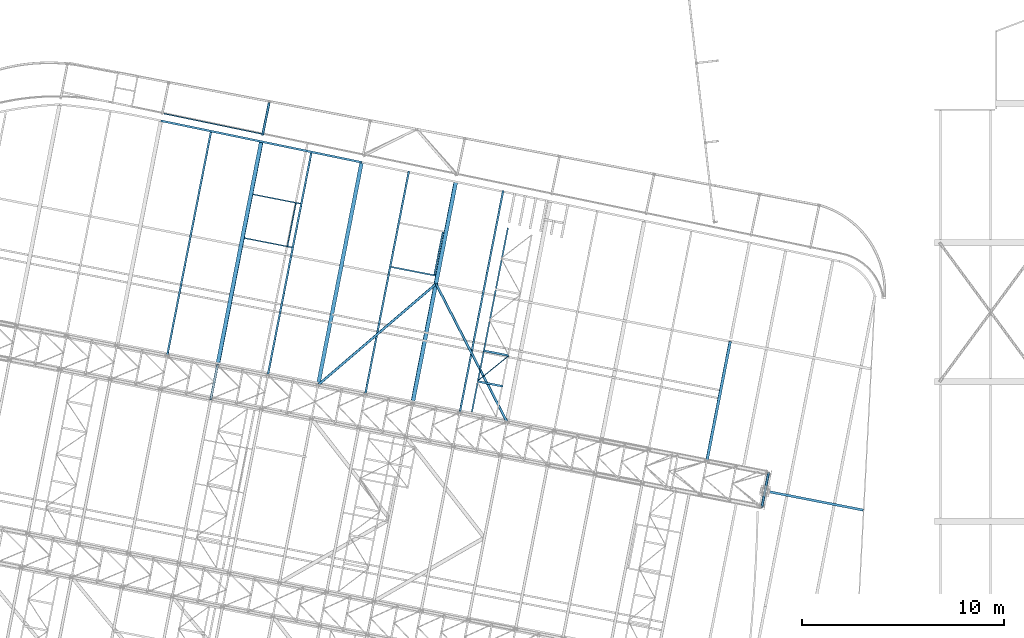
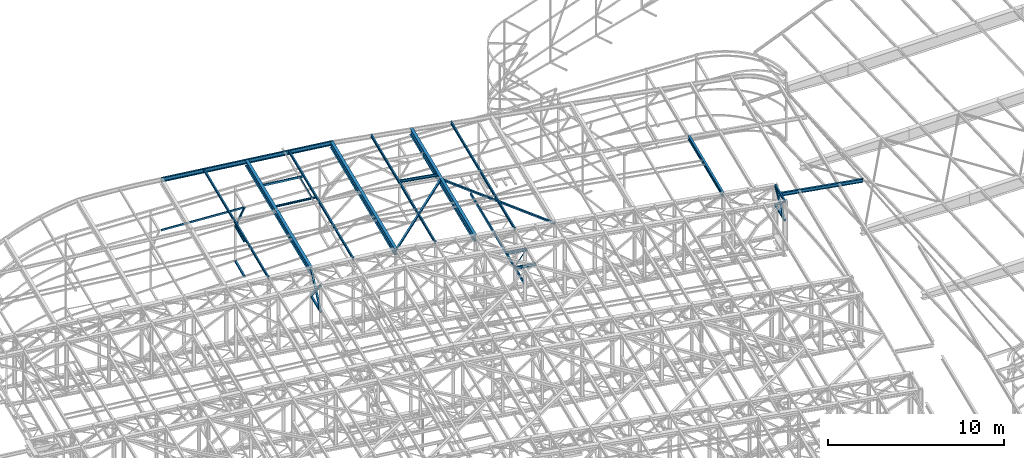
# One storey, part 93 of 215: 27 beams, 5 members, 32 elements without a shape of their own.
"""IFC2X3 building model written with IfcOpenShell, lengths in millimetres."""

from ifc_helpers import new_model, si_unit, frame, origin_with_axes, origin_2d_with_axis, place, context, subcontext, project, spatial, hollow_rectangle, i_section, u_section, extrude, clip, halfspace, material, type_object, element, aggregate, save


model = new_model("IFC2X3")

# Units and contexts
model_context = context("Model", 3, precision=1e-05, world=origin_with_axes())
body_context = subcontext(model_context, "Body", "Model", "MODEL_VIEW")
ifc_project = project(units=[si_unit("LENGTHUNIT", "METRE", prefix="MILLI"), si_unit("AREAUNIT", "SQUARE_METRE"), si_unit("VOLUMEUNIT", "CUBIC_METRE"), si_unit("MASSUNIT", "GRAM", prefix="KILO"), si_unit("TIMEUNIT", "SECOND"), si_unit("PLANEANGLEUNIT", "RADIAN"), si_unit("SOLIDANGLEUNIT", "STERADIAN"), si_unit("THERMODYNAMICTEMPERATUREUNIT", "DEGREE_CELSIUS"), si_unit("LUMINOUSINTENSITYUNIT", "LUMEN")], contexts=[model_context])

# Site, building, storey
site_placement = place(None, origin_with_axes())
site = spatial("IfcSite", under=ifc_project, at=site_placement, CompositionType="ELEMENT")
building_placement = place(site_placement, origin_with_axes())
building = spatial("IfcBuilding", under=site, at=building_placement, Name="Undefined", CompositionType="ELEMENT")
storey_placement = place(building_placement, origin_with_axes())
storey = spatial("IfcBuildingStorey", under=building, at=storey_placement, Name="Undefined", CompositionType="ELEMENT", Elevation=0.0)

# Assembly, beam
assembly_1_placement = place(storey_placement, origin_with_axes())
assembly_1 = element("IfcElementAssembly", 1, at=assembly_1_placement, inside=storey, Name="Steel Assembly", AssemblyPlace="NOTDEFINED", PredefinedType="RIGID_FRAME")
ifc_material_1 = material(Name="STEEL/S275JR")
beam_type_1 = type_object("IfcBeamType", Name="IPE240", PredefinedType="NOTDEFINED")
beam_1_placement = place(assembly_1_placement, frame((100333.854701752, 42404.6392452489, 11940.1366854716), z_axis=(0.0304080349965938, -0.00594450399933318, 0.999519891888024), x_axis=(-0.980951221876683, 0.191767344975893, 0.0309836359961049)))
beam_1 = element("IfcBeam", 2, at=beam_1_placement, type_object=beam_type_1, material=ifc_material_1, Name="TRAVERSE", ObjectType="IPE240", context=body_context, shape_type="SweptSolid", body=[
    extrude(i_section(OverallWidth=120.0, OverallDepth=240.0, WebThickness=6.199999809, FlangeThickness=9.800000191, FilletRadius=15.0, at=origin_2d_with_axis()), frame((5141.20801829548, 7.32585423039846e-12, 1.81898940354586e-12), z_axis=(-1.0, 0.0, 0.0), x_axis=(-6.93889390390723e-18, -1.0, -3.46944695195361e-18)), (0.0, 0.0, 1.0), 5141.2),
])
aggregate(assembly_1, [beam_1])

assembly_2_placement = place(storey_placement, origin_with_axes())
assembly_2 = element("IfcElementAssembly", 3, at=assembly_2_placement, inside=storey, Name="Steel Assembly", AssemblyPlace="NOTDEFINED", PredefinedType="RIGID_FRAME")
beam_type_2 = type_object("IfcBeamType", Name="IPE270", PredefinedType="NOTDEFINED")
beam_2_placement = place(assembly_2_placement, frame((92580.0306910129, 44842.2517101746, 12173.3292779215), z_axis=(0.0304082059912027, -0.00594365899827871, 0.99951989171107), x_axis=(0.19183216594908, 0.981427745739484, 0.0)))
beam_2 = element("IfcBeam", 4, at=beam_2_placement, type_object=beam_type_2, material=ifc_material_1, Name="POUTRE", ObjectType="IPE270", context=body_context, shape_type="SweptSolid", body=[
    extrude(i_section(OverallWidth=135.0, OverallDepth=270.0, WebThickness=6.599999905, FlangeThickness=10.19999981, FilletRadius=15.0, at=origin_2d_with_axis()), frame((6043.84248613371, 3.35500654265671e-13, -5.2421977229011e-15), z_axis=(-1.0, 0.0, 0.0), x_axis=(-6.93889390390723e-18, -1.0, -3.46944695195361e-18)), (0.0, 0.0, 1.0), 6043.8),
])
aggregate(assembly_2, [beam_2])

assembly_3_placement = place(storey_placement, origin_with_axes())
assembly_3 = element("IfcElementAssembly", 5, at=assembly_3_placement, inside=storey, Name="Steel Assembly", AssemblyPlace="NOTDEFINED", PredefinedType="RIGID_FRAME")
beam_type_3 = type_object("IfcBeamType", PredefinedType="NOTDEFINED")
beam_3_placement = place(assembly_3_placement, frame((95313.7951535351, 42575.6449936829, 10796.0000007593), z_axis=(0.981422364268518, -0.191859461052493, -0.000300197000082615), x_axis=(0.191859470081235, 0.981422408415534, 0.0)))
beam_3 = element("IfcBeam", 6, at=beam_3_placement, type_object=beam_type_3, material=ifc_material_1, context=body_context, shape_type="SweptSolid", body=[
    extrude(hollow_rectangle(XDim=120.0, YDim=120.0, WallThickness=5.0, InnerFilletRadius=5.0, OuterFilletRadius=10.0, at=origin_2d_with_axis()), frame((1699.99999941724, 1.81898940354586e-12, 0.0), z_axis=(-1.0, 0.0, 0.0), x_axis=(-6.93889390390723e-18, -1.0, -3.46944695195361e-18)), (0.0, 0.0, 1.0), 1700.0),
])
aggregate(assembly_3, [beam_3])

assembly_4_placement = place(storey_placement, origin_with_axes())
assembly_4 = element("IfcElementAssembly", 7, at=assembly_4_placement, inside=storey, Name="Steel Assembly", AssemblyPlace="NOTDEFINED", PredefinedType="RIGID_FRAME")
beam_4_placement = place(assembly_4_placement, frame((67973.1953593636, 47920.4920874086, 10796.0000009293), z_axis=(0.981422364268518, -0.191859461052493, -0.000300197000082615), x_axis=(0.191859470081235, 0.981422408415534, 0.0)))
beam_4 = element("IfcBeam", 8, at=beam_4_placement, type_object=beam_type_3, material=ifc_material_1, context=body_context, shape_type="SweptSolid", body=[
    extrude(hollow_rectangle(XDim=120.0, YDim=120.0, WallThickness=5.0, InnerFilletRadius=5.0, OuterFilletRadius=10.0, at=origin_2d_with_axis()), frame((1699.99999941724, 1.81898940354586e-12, 0.0), z_axis=(-1.0, 0.0, 0.0), x_axis=(-6.93889390390723e-18, -1.0, -3.46944695195361e-18)), (0.0, 0.0, 1.0), 1700.0),
])
aggregate(assembly_4, [beam_4])

assembly_5_placement = place(storey_placement, origin_with_axes())
assembly_5 = element("IfcElementAssembly", 9, at=assembly_5_placement, inside=storey, Name="Steel Assembly", AssemblyPlace="NOTDEFINED", PredefinedType="RIGID_FRAME")
beam_5_placement = place(assembly_5_placement, frame((82664.0569124104, 46780.7374344167, 12488.7228288463), z_axis=(0.0309053849882418, -0.00568770899783306, 0.999506131619554), x_axis=(-0.457200199871829, 0.889156602750736, 0.0191966929946186)))
beam_5 = element("IfcBeam", 10, at=beam_5_placement, type_object=beam_type_3, material=ifc_material_1, context=body_context, shape_type="SweptSolid", body=[
    extrude(hollow_rectangle(XDim=120.0, YDim=120.0, WallThickness=5.0, InnerFilletRadius=5.0, OuterFilletRadius=10.0, at=origin_2d_with_axis()), frame((7699.95057306601, -1.54238954912719e-11, 0.0), z_axis=(-1.0, 0.0, 0.0), x_axis=(-6.93889390390723e-18, -1.0, -3.46944695195361e-18)), (0.0, 0.0, 1.0), 7700.0),
])
aggregate(assembly_5, [beam_5])

assembly_6_placement = place(storey_placement, origin_with_axes())
assembly_6 = element("IfcElementAssembly", 11, at=assembly_6_placement, inside=storey, Name="Steel Assembly", AssemblyPlace="NOTDEFINED", PredefinedType="RIGID_FRAME")
beam_6_placement = place(assembly_6_placement, frame((79143.637973717, 53627.199327827, 12636.536425122), z_axis=(0.0308190389945567, -0.00642397899886577, 0.999504336823645), x_axis=(-0.759483473973753, -0.650242043977528, 0.0192389449993352)))
beam_6 = element("IfcBeam", 12, at=beam_6_placement, type_object=beam_type_3, material=ifc_material_1, context=body_context, shape_type="SweptSolid", body=[
    extrude(hollow_rectangle(XDim=120.0, YDim=120.0, WallThickness=5.0, InnerFilletRadius=5.0, OuterFilletRadius=10.0, at=origin_2d_with_axis()), frame((7710.20406856117, 3.60495909808602e-12, 2.67501440046099e-14), z_axis=(-1.0, 0.0, 0.0), x_axis=(-6.93889390390723e-18, -1.0, -3.46944695195361e-18)), (0.0, 0.0, 1.0), 7710.2),
])
aggregate(assembly_6, [beam_6])

assembly_7_placement = place(storey_placement, origin_with_axes())
assembly_7 = element("IfcElementAssembly", 13, at=assembly_7_placement, inside=storey, Name="Steel Assembly", AssemblyPlace="NOTDEFINED", PredefinedType="RIGID_FRAME")
beam_7_placement = place(assembly_7_placement, frame((70863.0917955773, 62610.270915588, 6831.83160072368), z_axis=(0.97957922139794, -0.201058571081677, 0.0), x_axis=(-0.201058572041247, -0.979579221200988, -1.00000033874093e-09)))
beam_7 = element("IfcBeam", 14, at=beam_7_placement, type_object=beam_type_3, material=ifc_material_1, context=body_context, shape_type="SweptSolid", body=[
    extrude(hollow_rectangle(XDim=120.0, YDim=120.0, WallThickness=5.0, InnerFilletRadius=5.0, OuterFilletRadius=10.0, at=origin_2d_with_axis()), frame((1609.80539167399, 0.0, 4.46810752750545e-14), z_axis=(-1.0, 0.0, 0.0), x_axis=(-6.93889390390723e-18, -1.0, -3.46944695195361e-18)), (0.0, 0.0, 1.0), 1609.8),
])
aggregate(assembly_7, [beam_7])

assembly_8_placement = place(storey_placement, origin_with_axes())
assembly_8 = element("IfcElementAssembly", 15, at=assembly_8_placement, inside=storey, Name="Steel Assembly", AssemblyPlace="NOTDEFINED", PredefinedType="RIGID_FRAME")
beam_8_placement = place(assembly_8_placement, frame((70863.0917957025, 62610.2709179184, 4396.61258558344), z_axis=(0.97957922139794, -0.201058571081677, 0.0), x_axis=(-0.201058572041247, -0.979579221200988, -1.00000033874093e-09)))
beam_8 = element("IfcBeam", 16, at=beam_8_placement, type_object=beam_type_3, material=ifc_material_1, context=body_context, shape_type="SweptSolid", body=[
    extrude(hollow_rectangle(XDim=120.0, YDim=120.0, WallThickness=5.0, InnerFilletRadius=5.0, OuterFilletRadius=10.0, at=origin_2d_with_axis()), frame((1609.80539167399, 0.0, 4.46810752750545e-14), z_axis=(-1.0, 0.0, 0.0), x_axis=(-6.93889390390723e-18, -1.0, -3.46944695195361e-18)), (0.0, 0.0, 1.0), 1609.8),
])
aggregate(assembly_8, [beam_8])

assembly_9_placement = place(storey_placement, origin_with_axes())
assembly_9 = element("IfcElementAssembly", 17, at=assembly_9_placement, inside=storey, Name="Steel Assembly", AssemblyPlace="NOTDEFINED", PredefinedType="RIGID_FRAME")
beam_type_4 = type_object("IfcBeamType", PredefinedType="NOTDEFINED")
beam_9_placement = place(assembly_9_placement, frame((82757.833919261, 50069.6730803142, 8745.0), z_axis=(0.0, 0.0, -1.0), x_axis=(-0.777591169660664, -0.628770206725606, 0.0)))
beam_9 = element("IfcBeam", 18, at=beam_9_placement, type_object=beam_type_4, material=ifc_material_1, context=body_context, shape_type="SweptSolid", body=[
    extrude(hollow_rectangle(XDim=50.0, YDim=50.0, WallThickness=3.0, InnerFilletRadius=3.0, OuterFilletRadius=6.0, at=origin_2d_with_axis()), frame((2026.56718786147, 2.24994155291366e-13, 0.0), z_axis=(-1.0, 0.0, 0.0), x_axis=(-6.93889390390723e-18, -1.0, -3.46944695195361e-18)), (0.0, 0.0, 1.0), 2026.6),
])
aggregate(assembly_9, [beam_9])

assembly_10_placement = place(storey_placement, origin_with_axes())
assembly_10 = element("IfcElementAssembly", 19, at=assembly_10_placement, inside=storey, Name="Steel Assembly", AssemblyPlace="NOTDEFINED", PredefinedType="RIGID_FRAME")
ifc_material_2 = material(Name="STEEL/S235JR")
beam_type_5 = type_object("IfcBeamType", Name="UPN140", PredefinedType="NOTDEFINED")
beam_10_placement = place(assembly_10_placement, frame((71776.5816321389, 55512.8253533276, 12762.630425367), z_axis=(-0.0304080349967745, 0.00594450299936818, 0.999519891893966), x_axis=(0.191880718074391, 0.981418254380493, 4.40000000352173e-08)))
beam_10 = element("IfcBeam", 20, at=beam_10_placement, type_object=beam_type_5, material=ifc_material_2, ObjectType="UPN140", context=body_context, shape_type="SweptSolid", body=[
    extrude(u_section(Depth=140.0, FlangeWidth=60.0, WebThickness=7.0, FlangeThickness=10.0, FilletRadius=10.0, EdgeRadius=5.0, FlangeSlope=0.0798299857122373, at=origin_2d_with_axis()), frame((2150.00349895753, 7.23853232835043e-12, -2.08044720554876e-15), z_axis=(-1.0, 0.0, 0.0), x_axis=(-6.93889390390723e-18, -1.0, -3.46944695195361e-18)), (0.0, 0.0, 1.0), 2150.0),
])
aggregate(assembly_10, [beam_10])

assembly_11_placement = place(storey_placement, origin_with_axes())
assembly_11 = element("IfcElementAssembly", 21, at=assembly_11_placement, inside=storey, Name="Steel Assembly", AssemblyPlace="NOTDEFINED", PredefinedType="RIGID_FRAME")
beam_11_placement = place(assembly_11_placement, frame((72414.8150174794, 57609.3254937928, 12769.5771667052), z_axis=(-0.0304080349967745, 0.00594450299936818, 0.999519891893966), x_axis=(-0.980947279001733, 0.191787511000338, -0.0309836480000548)))
beam_11 = element("IfcBeam", 22, at=beam_11_placement, type_object=beam_type_5, material=ifc_material_2, ObjectType="UPN140", context=body_context, shape_type="SweptSolid", body=[
    extrude(u_section(Depth=140.0, FlangeWidth=60.0, WebThickness=7.0, FlangeThickness=10.0, FilletRadius=10.0, EdgeRadius=5.0, FlangeSlope=0.0798299857122373, at=origin_2d_with_axis()), frame((2404.26612991932, -3.62067344519824e-12, -8.34147379613389e-15), z_axis=(-1.0, 0.0, 0.0), x_axis=(-6.93889390390723e-18, -1.0, -3.46944695195361e-18)), (0.0, 0.0, 1.0), 2404.3),
])
aggregate(assembly_11, [beam_11])

assembly_12_placement = place(storey_placement, origin_with_axes())
assembly_12 = element("IfcElementAssembly", 23, at=assembly_12_placement, inside=storey, Name="Steel Assembly", AssemblyPlace="NOTDEFINED", PredefinedType="RIGID_FRAME")
beam_12_placement = place(assembly_12_placement, frame((69632.3812784138, 55901.4799928679, 12695.0867127076), z_axis=(-0.0304080349967745, 0.00594450299936818, 0.999519891893966), x_axis=(0.9809472788136, -0.191787511963556, 0.0309836479941128)))
beam_12 = element("IfcBeam", 24, at=beam_12_placement, type_object=beam_type_5, material=ifc_material_2, ObjectType="UPN140", context=body_context, shape_type="SweptSolid", body=[
    extrude(u_section(Depth=140.0, FlangeWidth=60.0, WebThickness=7.0, FlangeThickness=10.0, FilletRadius=10.0, EdgeRadius=5.0, FlangeSlope=0.0798299857122373, at=origin_2d_with_axis()), frame((2404.26547487024, -4.76208710676447e-14, 1.81898940354586e-12), z_axis=(-1.0, 0.0, 0.0), x_axis=(-6.93889390390723e-18, -1.0, -3.46944695195361e-18)), (0.0, 0.0, 1.0), 2404.3),
])
aggregate(assembly_12, [beam_12])

assembly_13_placement = place(storey_placement, origin_with_axes())
assembly_13 = element("IfcElementAssembly", 25, at=assembly_13_placement, inside=storey, Name="Steel Assembly", AssemblyPlace="NOTDEFINED", PredefinedType="RIGID_FRAME")
beam_type_6 = type_object("IfcBeamType", Name="IPE180", PredefinedType="NOTDEFINED")
beam_13_placement = place(assembly_13_placement, frame((95637.6544010324, 44244.5132835762, 12123.9695153452), z_axis=(0.0304080349965938, -0.00594450399933318, 0.999519891888024), x_axis=(-0.192137851067204, -0.981367946343237, 8.79400000299341e-06)))
beam_13 = element("IfcBeam", 26, at=beam_13_placement, type_object=beam_type_6, material=ifc_material_1, ObjectType="IPE180", context=body_context, shape_type="SweptSolid", body=[
    extrude(i_section(OverallWidth=91.0, OverallDepth=180.0, WebThickness=5.300000191, FlangeThickness=8.0, FilletRadius=9.0, at=origin_2d_with_axis()), frame((1699.99999941724, 1.81898940354586e-12, 0.0), z_axis=(-1.0, 0.0, 0.0), x_axis=(-6.93889390390723e-18, -1.0, -3.46944695195361e-18)), (0.0, 0.0, 1.0), 1700.0),
])
aggregate(assembly_13, [beam_13])

assembly_14_placement = place(storey_placement, origin_with_axes())
assembly_14 = element("IfcElementAssembly", 27, at=assembly_14_placement, inside=storey, Name="Steel Assembly", AssemblyPlace="NOTDEFINED", PredefinedType="RIGID_FRAME")
beam_14_placement = place(assembly_14_placement, frame((65806.0371301405, 50076.332289581, 12593.3189656953), z_axis=(-0.0304080349967745, 0.00594450299936818, 0.999519891893966), x_axis=(0.191845211931802, 0.981425195651121, 9.9999994476379e-10)))
beam_14 = element("IfcBeam", 28, at=beam_14_placement, type_object=beam_type_6, material=ifc_material_1, ObjectType="IPE180", context=body_context, shape_type="Clipping", body=[
    clip(extrude(i_section(OverallWidth=91.0, OverallDepth=180.0, WebThickness=5.300000191, FlangeThickness=8.0, FilletRadius=9.0, at=origin_2d_with_axis()), frame((11427.4744471864, -7.33938858746666e-12, 9.32355752363314e-17), z_axis=(-1.0, 0.0, 0.0), x_axis=(-6.93889390390723e-18, -1.0, -3.46944695195361e-18)), (0.0, 0.0, 1.0), 11427.5), halfspace(frame((11391.5562804669, 506.900317026499, -12583.6548768152), z_axis=(-0.999938182549774, 0.0111136130355259, 0.000344505954069754), x_axis=(4.11426299251616e-10, -0.0309836361466733, 0.999519891893669)), True)),
])
aggregate(assembly_14, [beam_14])

assembly_15_placement = place(storey_placement, origin_with_axes())
assembly_15 = element("IfcElementAssembly", 29, at=assembly_15_placement, inside=storey, Name="Steel Assembly", AssemblyPlace="NOTDEFINED", PredefinedType="RIGID_FRAME")
beam_15_placement = place(assembly_15_placement, frame((70798.4859484614, 49100.3523215424, 12751.0069482676), z_axis=(-0.0304080349967745, 0.00594450299936818, 0.999519891893966), x_axis=(0.191845211931802, 0.981425195651121, 9.9999994476379e-10)))
beam_15 = element("IfcBeam", 30, at=beam_15_placement, type_object=beam_type_6, material=ifc_material_1, ObjectType="IPE180", context=body_context, shape_type="Clipping", body=[
    clip(extrude(i_section(OverallWidth=91.0, OverallDepth=180.0, WebThickness=5.300000191, FlangeThickness=8.0, FilletRadius=9.0, at=origin_2d_with_axis()), frame((11370.9839497757, -7.65468305737661e-12, 1.8092139170416e-12), z_axis=(-1.0, 0.0, 0.0), x_axis=(-6.93889390390723e-18, -1.0, -3.46944695195361e-18)), (0.0, 0.0, 1.0), 11371.0), halfspace(frame((11335.1302808044, 517.583630821922, -12741.0874360714), z_axis=(-0.999938182549774, 0.0111136130355259, 0.000344505954069754), x_axis=(4.11426299251616e-10, -0.0309836361466733, 0.999519891893669)), True)),
])
aggregate(assembly_15, [beam_15])

assembly_16_placement = place(storey_placement, origin_with_axes())
assembly_16 = element("IfcElementAssembly", 31, at=assembly_16_placement, inside=storey, Name="Steel Assembly", AssemblyPlace="NOTDEFINED", PredefinedType="RIGID_FRAME")
beam_16_placement = place(assembly_16_placement, frame((80321.3773635057, 47238.7105899391, 12607.738701104), z_axis=(0.0304080349965938, -0.00594450399933318, 0.999519891888024), x_axis=(0.191845211931802, 0.981425195651121, 9.9999994476379e-10)))
beam_16 = element("IfcBeam", 32, at=beam_16_placement, type_object=beam_type_6, material=ifc_material_1, ObjectType="IPE180", context=body_context, shape_type="Clipping", body=[
    clip(extrude(i_section(OverallWidth=91.0, OverallDepth=180.0, WebThickness=5.300000191, FlangeThickness=8.0, FilletRadius=9.0, at=origin_2d_with_axis()), frame((11263.236963052, -3.12617625204737e-13, 1.8287587043335e-12), z_axis=(-1.0, 0.0, 0.0), x_axis=(-6.93889390390723e-18, -1.0, -3.46944695195361e-18)), (0.0, 0.0, 1.0), 11263.2), halfspace(frame((11225.1365867955, -470.077614428155, -12599.2229764053), z_axis=(-0.999938182878617, 0.0111135834721958, -0.00034450517658452), x_axis=(-1.11477173049934e-07, 0.0309836363285431, 0.999519891888024)), True)),
])
aggregate(assembly_16, [beam_16])

assembly_17_placement = place(storey_placement, origin_with_axes())
assembly_17 = element("IfcElementAssembly", 33, at=assembly_17_placement, inside=storey, Name="Steel Assembly", AssemblyPlace="NOTDEFINED", PredefinedType="RIGID_FRAME")
beam_17_placement = place(assembly_17_placement, frame((75633.2832000146, 48155.1918914293, 12755.813545489), z_axis=(0.0304080349965938, -0.00594450399933318, 0.999519891888024), x_axis=(0.191845211931802, 0.981425195651121, 9.9999994476379e-10)))
beam_17 = element("IfcBeam", 34, at=beam_17_placement, type_object=beam_type_6, material=ifc_material_1, ObjectType="IPE180", context=body_context, shape_type="Clipping", body=[
    clip(extrude(i_section(OverallWidth=91.0, OverallDepth=180.0, WebThickness=5.300000191, FlangeThickness=8.0, FilletRadius=9.0, at=origin_2d_with_axis()), frame((11316.2828768343, -7.27595761418343e-12, -1.81898940354586e-12), z_axis=(-1.0, 0.0, 0.0), x_axis=(-6.93889390390723e-18, -1.0, -3.46944695195361e-18)), (0.0, 0.0, 1.0), 11316.3), halfspace(frame((11280.3234000167, -282.224260773233, -12753.1921226253), z_axis=(-0.999938182878617, 0.0111135834721958, -0.00034450517658452), x_axis=(-1.11477173049934e-07, 0.0309836363285431, 0.999519891888024)), True)),
])
aggregate(assembly_17, [beam_17])

assembly_18_placement = place(storey_placement, origin_with_axes())
assembly_18 = element("IfcElementAssembly", 35, at=assembly_18_placement, inside=storey, Name="Steel Assembly", AssemblyPlace="NOTDEFINED", PredefinedType="RIGID_FRAME")
beam_type_7 = type_object("IfcBeamType", Name="UPN200", PredefinedType="NOTDEFINED")
beam_18_placement = place(assembly_18_placement, frame((82708.5136857553, 56408.5565219196, 8670.00000002195), z_axis=(0.0, 0.0, -1.0), x_axis=(-0.191860814904866, -0.981422145513357, 0.0)))
beam_18 = element("IfcBeam", 36, at=beam_18_placement, type_object=beam_type_7, material=ifc_material_1, ObjectType="UPN200", context=body_context, shape_type="SweptSolid", body=[
    extrude(u_section(Depth=200.0, FlangeWidth=75.0, WebThickness=8.5, FlangeThickness=11.5, FilletRadius=11.5, EdgeRadius=6.0, FlangeSlope=0.0798299857122373, at=origin_2d_with_axis()), frame((9317.48686990727, 0.0, 1.81898940354586e-12), z_axis=(-1.0, 0.0, 0.0), x_axis=(-6.93889390390723e-18, -1.0, -3.46944695195361e-18)), (0.0, 0.0, 1.0), 9317.5),
])
aggregate(assembly_18, [beam_18])

assembly_19_placement = place(storey_placement, origin_with_axes())
assembly_19 = element("IfcElementAssembly", 37, at=assembly_19_placement, inside=storey, Name="Steel Assembly", AssemblyPlace="NOTDEFINED", PredefinedType="RIGID_FRAME")
beam_19_placement = place(assembly_19_placement, frame((79066.7812709055, 54087.6577343977, 12676.6151780775), z_axis=(0.0304080349965938, -0.00594450399933318, 0.999519891888024), x_axis=(0.191859470081235, 0.981422408415534, 0.0)))
beam_19 = element("IfcBeam", 38, at=beam_19_placement, type_object=beam_type_7, material=ifc_material_2, ObjectType="UPN200", context=body_context, shape_type="SweptSolid", body=[
    extrude(u_section(Depth=200.0, FlangeWidth=75.0, WebThickness=8.5, FlangeThickness=11.5, FilletRadius=11.5, EdgeRadius=6.0, FlangeSlope=0.0798299857122373, at=origin_2d_with_axis()), frame((2149.96645748991, 6.98418044224936e-15, -1.81533901666633e-12), z_axis=(-1.0, 0.0, 0.0), x_axis=(-6.93889390390723e-18, -1.0, -3.46944695195361e-18)), (0.0, 0.0, 1.0), 2150.0),
])
aggregate(assembly_19, [beam_19])

assembly_20_placement = place(storey_placement, origin_with_axes())
assembly_20 = element("IfcElementAssembly", 39, at=assembly_20_placement, inside=storey, Name="Steel Assembly", AssemblyPlace="NOTDEFINED", PredefinedType="RIGID_FRAME")
beam_20_placement = place(assembly_20_placement, frame((76913.7765284455, 54470.3836098778, 12744.4165316083), z_axis=(0.0304080349965938, -0.00594450399933318, 0.999519891888024), x_axis=(0.980947274706054, -0.191787533942531, -0.0309836419907153)))
beam_20 = element("IfcBeam", 40, at=beam_20_placement, type_object=beam_type_7, material=ifc_material_2, ObjectType="UPN200", context=body_context, shape_type="SweptSolid", body=[
    extrude(u_section(Depth=200.0, FlangeWidth=75.0, WebThickness=8.5, FlangeThickness=11.5, FilletRadius=11.5, EdgeRadius=6.0, FlangeSlope=0.0798299857122373, at=origin_2d_with_axis()), frame((2249.04686463703, -3.60705473231594e-12, 7.80294878931578e-15), z_axis=(-1.0, 0.0, 0.0), x_axis=(-6.93889390390723e-18, -1.0, -3.46944695195361e-18)), (0.0, 0.0, 1.0), 2249.0),
])
aggregate(assembly_20, [beam_20])

# Assembly, member
assembly_21_placement = place(storey_placement, origin_with_axes())
assembly_21 = element("IfcElementAssembly", 41, at=assembly_21_placement, inside=storey, Name="Steel Assembly", AssemblyPlace="NOTDEFINED", PredefinedType="RIGID_FRAME")
member_type_1 = type_object("IfcMemberType", PredefinedType="NOTDEFINED")
member_1_placement = place(assembly_21_placement, frame((70539.4266253523, 61033.3390037475, 9192.72531547563), z_axis=(-0.979646109050852, 0.200732283010418, -0.000227110000011602), x_axis=(0.113268746055983, 0.551857650272743, -0.826210218408337)))
member_1 = element("IfcMember", 42, at=member_1_placement, type_object=member_type_1, material=ifc_material_1, context=body_context, shape_type="SweptSolid", body=[
    extrude(hollow_rectangle(XDim=100.0, YDim=100.0, WallThickness=5.0, InnerFilletRadius=5.0, OuterFilletRadius=10.0, at=origin_2d_with_axis()), frame((2857.49759798118, 1.47105382096713e-11, -7.40243775503803e-12), z_axis=(-1.0, 0.0, 0.0), x_axis=(-6.93889390390723e-18, -1.0, -3.46944695195361e-18)), (0.0, 0.0, 1.0), 2857.5),
])
aggregate(assembly_21, [member_1])

assembly_22_placement = place(storey_placement, origin_with_axes())
assembly_22 = element("IfcElementAssembly", 43, at=assembly_22_placement, inside=storey, Name="Steel Assembly", AssemblyPlace="NOTDEFINED", PredefinedType="RIGID_FRAME")
member_type_2 = type_object("IfcMemberType", PredefinedType="NOTDEFINED")
member_2_placement = place(assembly_22_placement, frame((95639.9562520427, 44244.0630874437, 10796.0000011487), z_axis=(0.981457773618154, -0.191678330925429, 0.000236765999907874), x_axis=(-0.151318402977677, -0.774041917885817, 0.614786019909311)))
member_2 = element("IfcMember", 44, at=member_2_placement, type_object=member_type_2, material=ifc_material_1, context=body_context, shape_type="SweptSolid", body=[
    extrude(hollow_rectangle(XDim=120.0, YDim=120.0, WallThickness=5.0, InnerFilletRadius=5.0, OuterFilletRadius=10.0, at=origin_2d_with_axis()), frame((2155.46218725893, 1.44322630409167e-11, -1.45888391455878e-11), z_axis=(-1.0, 0.0, 0.0), x_axis=(-6.93889390390723e-18, -1.0, -3.46944695195361e-18)), (0.0, 0.0, 1.0), 2155.5),
])
aggregate(assembly_22, [member_2])

assembly_23_placement = place(storey_placement, origin_with_axes())
assembly_23 = element("IfcElementAssembly", 45, at=assembly_23_placement, inside=storey, Name="Steel Assembly", AssemblyPlace="NOTDEFINED", PredefinedType="RIGID_FRAME")
member_3_placement = place(assembly_23_placement, frame((95313.7951535351, 42575.6449936829, 10796.0000007593), z_axis=(0.981457773617921, -0.191678330925384, -0.000236766999908156), x_axis=(0.151318403975515, 0.774041920874749, 0.614786015900518)))
member_3 = element("IfcMember", 46, at=member_3_placement, type_object=member_type_2, material=ifc_material_1, context=body_context, shape_type="SweptSolid", body=[
    extrude(hollow_rectangle(XDim=120.0, YDim=120.0, WallThickness=5.0, InnerFilletRadius=5.0, OuterFilletRadius=10.0, at=origin_2d_with_axis()), frame((2155.46218725893, 1.44322630409167e-11, -1.45888391455878e-11), z_axis=(-1.0, 0.0, 0.0), x_axis=(-6.93889390390723e-18, -1.0, -3.46944695195361e-18)), (0.0, 0.0, 1.0), 2155.5),
])
aggregate(assembly_23, [member_3])

assembly_24_placement = place(storey_placement, origin_with_axes())
assembly_24 = element("IfcElementAssembly", 47, at=assembly_24_placement, inside=storey, Name="Steel Assembly", AssemblyPlace="NOTDEFINED", PredefinedType="RIGID_FRAME")
member_4_placement = place(assembly_24_placement, frame((68299.3564580423, 49588.9101812269, 10796.0000009276), z_axis=(0.981465045882622, -0.191641130977078, 0.000201564999975286), x_axis=(-0.128822807021333, -0.658969764109112, 0.741055689122704)))
member_4 = element("IfcMember", 48, at=member_4_placement, type_object=member_type_2, material=ifc_material_1, context=body_context, shape_type="SweptSolid", body=[
    extrude(hollow_rectangle(XDim=120.0, YDim=120.0, WallThickness=5.0, InnerFilletRadius=5.0, OuterFilletRadius=10.0, at=origin_2d_with_axis()), frame((2531.85832868423, -6.99486487302401e-12, 7.33099579250614e-12), z_axis=(-1.0, 0.0, 0.0), x_axis=(-6.93889390390723e-18, -1.0, -3.46944695195361e-18)), (0.0, 0.0, 1.0), 2531.9),
])
aggregate(assembly_24, [member_4])

assembly_25_placement = place(storey_placement, origin_with_axes())
assembly_25 = element("IfcElementAssembly", 49, at=assembly_25_placement, inside=storey, Name="Steel Assembly", AssemblyPlace="NOTDEFINED", PredefinedType="RIGID_FRAME")
member_5_placement = place(assembly_25_placement, frame((67973.1953593636, 47920.4920874086, 10796.0000009293), z_axis=(0.981465045882622, -0.191641130977078, -0.000201564999975286), x_axis=(0.128822807951567, 0.658969767752257, 0.741055685721397)))
member_5 = element("IfcMember", 50, at=member_5_placement, type_object=member_type_2, material=ifc_material_1, context=body_context, shape_type="SweptSolid", body=[
    extrude(hollow_rectangle(XDim=120.0, YDim=120.0, WallThickness=5.0, InnerFilletRadius=5.0, OuterFilletRadius=10.0, at=origin_2d_with_axis()), frame((2531.85832868423, -6.99486487302401e-12, 7.33099579250614e-12), z_axis=(-1.0, 0.0, 0.0), x_axis=(-6.93889390390723e-18, -1.0, -3.46944695195361e-18)), (0.0, 0.0, 1.0), 2531.9),
])
aggregate(assembly_25, [member_5])

# Assembly, beam
assembly_26_placement = place(storey_placement, origin_with_axes())
assembly_26 = element("IfcElementAssembly", 51, at=assembly_26_placement, inside=storey, Name="Steel Assembly", AssemblyPlace="NOTDEFINED", PredefinedType="RIGID_FRAME")
beam_type_8 = type_object("IfcBeamType", Name="UPN120", PredefinedType="NOTDEFINED")
beam_21_placement = place(assembly_26_placement, frame((65654.6324184104, 62073.2634513377, 8686.64667311346), z_axis=(0.0954927630220553, -0.0198170630045788, -0.995232845229842), x_axis=(0.974470600214969, -0.202226273044611, 0.0975273490215146)))
beam_21 = element("IfcBeam", 52, at=beam_21_placement, type_object=beam_type_8, material=ifc_material_1, ObjectType="UPN120", context=body_context, shape_type="SweptSolid", body=[
    extrude(u_section(Depth=120.0, FlangeWidth=55.0, WebThickness=7.0, FlangeThickness=9.0, FilletRadius=9.0, EdgeRadius=4.5, FlangeSlope=0.0798299857122373, at=origin_2d_with_axis()), frame((4965.5577994671, -4.60848042323206e-14, -6.89109574884423e-14), z_axis=(-1.0, 0.0, 0.0), x_axis=(-6.93889390390723e-18, -1.0, -3.46944695195361e-18)), (0.0, 0.0, 1.0), 4965.6),
])
aggregate(assembly_26, [beam_21])

assembly_27_placement = place(storey_placement, origin_with_axes())
assembly_27 = element("IfcElementAssembly", 53, at=assembly_27_placement, inside=storey, Name="Steel Assembly", AssemblyPlace="NOTDEFINED", PredefinedType="RIGID_FRAME")
beam_type_9 = type_object("IfcBeamType", Name="IPE200", PredefinedType="NOTDEFINED")
beam_22_placement = place(assembly_27_placement, frame((82757.8339192277, 50069.6730801397, 8670.00000000005), z_axis=(0.0, 0.0, -1.0), x_axis=(-0.981422136295317, 0.191860862057732, 0.0)))
beam_22 = element("IfcBeam", 54, at=beam_22_placement, type_object=beam_type_9, material=ifc_material_1, ObjectType="IPE200", context=body_context, shape_type="SweptSolid", body=[
    extrude(i_section(OverallWidth=100.0, OverallDepth=200.0, WebThickness=5.599999905, FlangeThickness=8.5, FilletRadius=12.0, at=origin_2d_with_axis()), frame((1302.08731245854, -3.61401828590942e-14, 0.0), z_axis=(-1.0, 0.0, 0.0), x_axis=(-6.93889390390723e-18, -1.0, -3.46944695195361e-18)), (0.0, 0.0, 1.0), 1302.1),
])
aggregate(assembly_27, [beam_22])

assembly_28_placement = place(storey_placement, origin_with_axes())
assembly_28 = element("IfcElementAssembly", 55, at=assembly_28_placement, inside=storey, Name="Steel Assembly", AssemblyPlace="NOTDEFINED", PredefinedType="RIGID_FRAME")
beam_23_placement = place(assembly_28_placement, frame((82459.8904813215, 48545.6084178077, 8670.00000000005), z_axis=(0.0, 0.0, -1.0), x_axis=(-0.981422136295317, 0.191860862057732, 0.0)))
beam_23 = element("IfcBeam", 56, at=beam_23_placement, type_object=beam_type_9, material=ifc_material_1, ObjectType="IPE200", context=body_context, shape_type="SweptSolid", body=[
    extrude(i_section(OverallWidth=100.0, OverallDepth=200.0, WebThickness=5.599999905, FlangeThickness=8.5, FilletRadius=12.0, at=origin_2d_with_axis()), frame((1302.08731245854, -3.61401828590942e-14, 0.0), z_axis=(-1.0, 0.0, 0.0), x_axis=(-6.93889390390723e-18, -1.0, -3.46944695195361e-18)), (0.0, 0.0, 1.0), 1302.1),
])
aggregate(assembly_28, [beam_23])

assembly_29_placement = place(storey_placement, origin_with_axes())
assembly_29 = element("IfcElementAssembly", 57, at=assembly_29_placement, inside=storey, Name="Steel Assembly", AssemblyPlace="NOTDEFINED", PredefinedType="RIGID_FRAME")
beam_type_10 = type_object("IfcBeamType", Name="UPE300", PredefinedType="NOTDEFINED")
beam_24_placement = place(assembly_29_placement, frame((65490.4453965468, 61721.729059186, 12454.4134709032), z_axis=(-0.0303401499972842, 0.00628179699944023, 0.999519891910411), x_axis=(0.978761297560689, -0.202648307909042, 0.0309836359860931)))
beam_24 = element("IfcBeam", 58, at=beam_24_placement, type_object=beam_type_10, material=ifc_material_1, Name="POUTRE", ObjectType="UPE300", context=body_context, shape_type="SweptSolid", body=[
    extrude(u_section(Depth=300.0, FlangeWidth=100.0, WebThickness=9.5, FlangeThickness=15.0, FilletRadius=15.0, at=origin_2d_with_axis()), frame((10181.7053719919, -3.73004180523142e-13, 1.81898940354586e-12), z_axis=(-1.0, 0.0, 0.0), x_axis=(-6.93889390390723e-18, -1.0, -3.46944695195361e-18)), (0.0, 0.0, 1.0), 10181.7),
])
aggregate(assembly_29, [beam_24])

assembly_30_placement = place(storey_placement, origin_with_axes())
assembly_30 = element("IfcElementAssembly", 59, at=assembly_30_placement, inside=storey, Name="Steel Assembly", AssemblyPlace="NOTDEFINED", PredefinedType="RIGID_FRAME")
beam_type_11 = type_object("IfcBeamType", Name="IPE450", PredefinedType="NOTDEFINED")
beam_25_placement = place(assembly_30_placement, frame((68306.3641028288, 49587.5402911885, 12535.1352802354), z_axis=(-0.0304080349967745, 0.00594450299936818, 0.999519891893966), x_axis=(0.191845211931802, 0.981425195651121, 9.9999994476379e-10)))
beam_25 = element("IfcBeam", 60, at=beam_25_placement, type_object=beam_type_11, material=ifc_material_1, Name="POUTRE", ObjectType="IPE450", context=body_context, shape_type="Clipping", body=[
    clip(extrude(i_section(OverallWidth=190.0, OverallDepth=450.0, WebThickness=9.399999619, FlangeThickness=14.60000038, FilletRadius=21.0, at=origin_2d_with_axis()), frame((11440.5607860533, 0.0, 3.63797880709171e-12), z_axis=(-1.0, 0.0, 0.0), x_axis=(-6.93889390390723e-18, -1.0, -3.46944695195361e-18)), (0.0, 0.0, 1.0), 11440.6), halfspace(frame((11364.3454600925, 601.812381044925, -12522.5010961668), z_axis=(-0.999938062210493, 0.0111244248229854, 0.000344840661627243), x_axis=(4.11426299251616e-10, -0.0309836361466733, 0.999519891893669)), True)),
])
aggregate(assembly_30, [beam_25])

assembly_31_placement = place(storey_placement, origin_with_axes())
assembly_31 = element("IfcElementAssembly", 61, at=assembly_31_placement, inside=storey, Name="Steel Assembly", AssemblyPlace="NOTDEFINED", PredefinedType="RIGID_FRAME")
beam_26_placement = place(assembly_31_placement, frame((77973.2273483625, 47697.7533268009, 12544.7484491346), z_axis=(0.0304080349965938, -0.00594450399933318, 0.999519891888024), x_axis=(0.191845211931802, 0.981425195651121, 9.9999994476379e-10)))
beam_26 = element("IfcBeam", 62, at=beam_26_placement, type_object=beam_type_11, material=ifc_material_1, Name="POUTRE", ObjectType="IPE450", context=body_context, shape_type="Clipping", body=[
    clip(extrude(i_section(OverallWidth=190.0, OverallDepth=450.0, WebThickness=9.399999619, FlangeThickness=14.60000038, FilletRadius=21.0, at=origin_2d_with_axis()), frame((11331.1415731367, 1.45519152283669e-11, -1.81898940354586e-12), z_axis=(-1.0, 0.0, 0.0), x_axis=(-6.93889390390723e-18, -1.0, -3.46944695195361e-18)), (0.0, 0.0, 1.0), 11331.1), halfspace(frame((11254.2161643612, -242.491930124845, -12543.2572877428), z_axis=(-0.999929332084094, 0.0118825570465701, -0.000368342086181548), x_axis=(-1.11477173049934e-07, 0.0309836363285431, 0.999519891888024)), True)),
])
aggregate(assembly_31, [beam_26])

assembly_32_placement = place(storey_placement, origin_with_axes())
assembly_32 = element("IfcElementAssembly", 63, at=assembly_32_placement, inside=storey, Name="Steel Assembly", AssemblyPlace="NOTDEFINED", PredefinedType="RIGID_FRAME")
beam_27_placement = place(assembly_32_placement, frame((73291.9734183281, 48612.8974092622, 12692.7153094397), z_axis=(0.0, 0.0, 1.0), x_axis=(0.191845211931802, 0.981425195651121, 9.9999994476379e-10)))
beam_27 = element("IfcBeam", 64, at=beam_27_placement, type_object=beam_type_11, material=ifc_material_1, Name="POUTRE", ObjectType="IPE450", context=body_context, shape_type="Clipping", body=[
    clip(extrude(i_section(OverallWidth=190.0, OverallDepth=450.0, WebThickness=9.399999619, FlangeThickness=14.60000038, FilletRadius=21.0, at=origin_2d_with_axis()), frame((11378.8047733551, -7.27595761418343e-12, 3.63797880709171e-12), z_axis=(-1.0, 0.0, 0.0), x_axis=(-6.93889390390723e-18, -1.0, -3.46944695195361e-18)), (0.0, 0.0, 1.0), 11378.8), halfspace(frame((11307.1474999939, 143.386472313257, -12692.7153094397), z_axis=(-0.999938358551333, 0.0111031120712241, 0.0), x_axis=(0.0, 0.0, 1.0)), True)),
])
aggregate(assembly_32, [beam_27])

save(model, "model.ifc")
